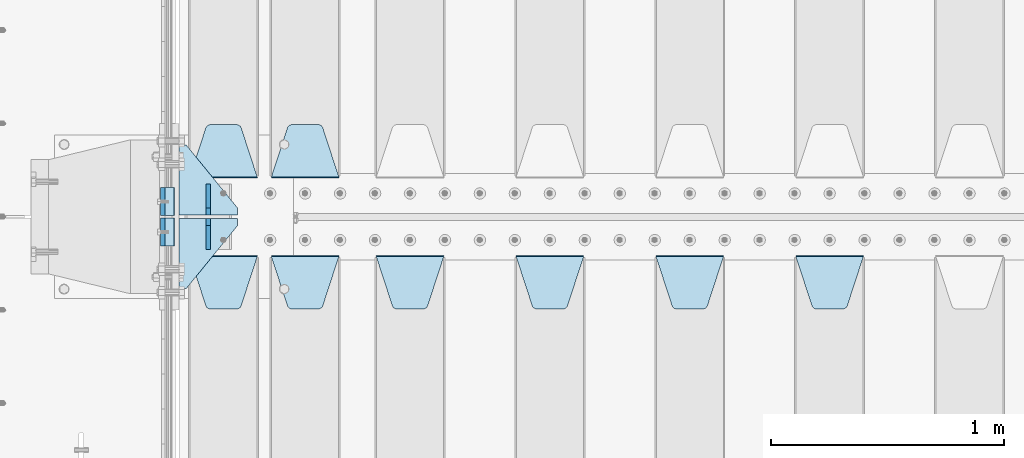
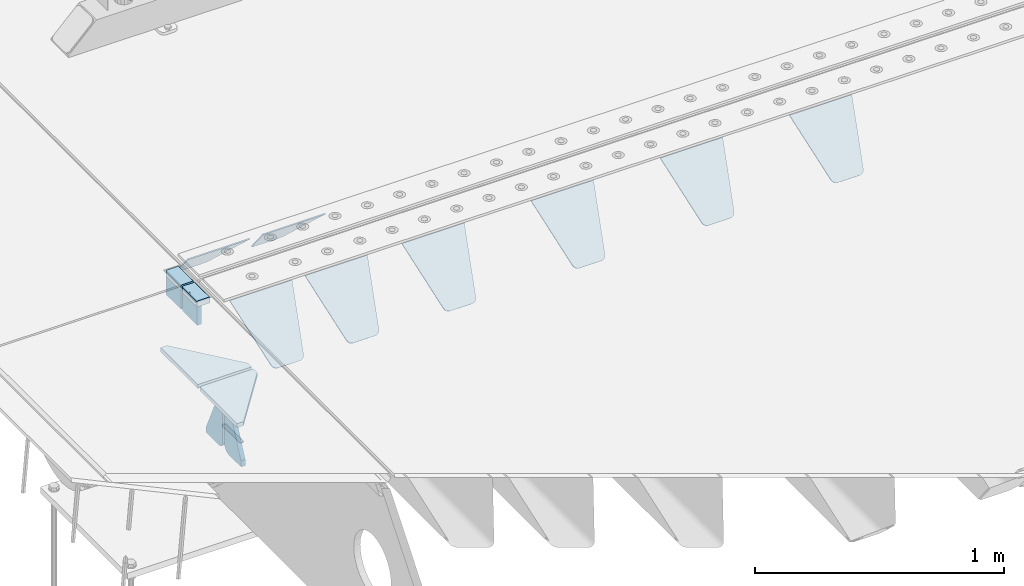
# One storey, part 217 of 257: 16 plates.
"""IFC2X3 building model written with IfcOpenShell, lengths in millimetres."""

from ifc_helpers import new_model, si_unit, frame, origin_with_axes, place, context, subcontext, project, spatial, faceted_brep, material, type_object, element, save


model = new_model("IFC2X3")

# Units and contexts
model_context = context("Model", 3, precision=1e-05, world=origin_with_axes())
body_context = subcontext(model_context, "Body", "Model", "MODEL_VIEW")
ifc_project = project(units=[si_unit("LENGTHUNIT", "METRE", prefix="MILLI"), si_unit("AREAUNIT", "SQUARE_METRE"), si_unit("VOLUMEUNIT", "CUBIC_METRE"), si_unit("MASSUNIT", "GRAM", prefix="KILO"), si_unit("TIMEUNIT", "SECOND"), si_unit("PLANEANGLEUNIT", "RADIAN"), si_unit("SOLIDANGLEUNIT", "STERADIAN"), si_unit("THERMODYNAMICTEMPERATUREUNIT", "DEGREE_CELSIUS"), si_unit("LUMINOUSINTENSITYUNIT", "LUMEN")], contexts=[model_context])

# Site, building, storey
site_placement = place(None, origin_with_axes())
site = spatial("IfcSite", under=ifc_project, at=site_placement, CompositionType="ELEMENT")
building_placement = place(site_placement, origin_with_axes())
building = spatial("IfcBuilding", under=site, at=building_placement, Name="Standard", CompositionType="ELEMENT")
storey_placement = place(building_placement, origin_with_axes())
storey = spatial("IfcBuildingStorey", under=building, at=storey_placement, Name="Undefined", CompositionType="ELEMENT", Elevation=0.0)

# Plates
ifc_material_1 = material()
plate_type_1 = type_object("IfcPlateType", PredefinedType="NOTDEFINED")
for number, where, z_axis, x_axis in (
    (1, (42440.00000006, 8935.00000043354, -16.000386849525), (-1.0, 0.0, 0.0), (0.0, -4.95099999998473e-06, 0.999999999987744)),
    (2, (42439.99999994, 9065.00000043201, -15.9997432191214), (-1.0, 0.0, 0.0), (0.0, -4.95099999998473e-06, 0.999999999987744)),
):
    element("IfcPlate", number, at=place(storey_placement, frame(where, z_axis=z_axis, x_axis=x_axis)), inside=storey, type_object=plate_type_1, material=ifc_material_1, context=body_context, shape_type="Brep", body=[
        faceted_brep([(0.0, -60.0, 0.0), (-0.000933120085687023, -60.0, 60.0), (-0.000933120085687023, 60.0, 59.9999999999927), (0.0, 60.0, -7.27595761418343e-12), (24.9991450303709, -60.0, 60.0), (24.9991450303709, 60.0, 59.9999999999927), (26.544215218168, -60.0, 59.7552873850873), (26.544215218168, 60.0, 59.75528738508), (27.9380461396139, -60.0, 59.0451032459096), (27.9380461396139, 60.0, 59.0451032459096), (29.0442025908961, -60.0, 57.9389639895744), (29.0442025908961, 60.0, 57.9389639895744), (29.7544083969366, -60.0, 56.5451441080368), (29.7544083969366, 60.0, 56.5451441080295), (29.9991450297669, -60.0, 55.0000777244568), (29.9991450297669, 60.0, 55.0000777244495), (29.999922274335, -60.0, 5.00007772445679), (29.999922274335, 60.0, 5.00007772444951), (29.7552240705896, -60.0, 3.45497416452417), (29.7552240705896, 60.0, 3.45497416452417), (29.0450346578116, -60.0, 2.06111146690819), (29.0450346578116, 60.0, 2.06111146690819), (27.9388736885072, -60.0, 0.954933302316931), (27.9388736885072, 60.0, 0.954933302316931), (26.5450220308766, -60.0, 0.244722222181736), (26.5450220308766, 60.0, 0.244722222181736), (24.9999222749392, -60.0, 0.0), (24.9999222749392, 60.0, -7.27595761418343e-12)], [[[0, 1, 2, 3]], [[1, 4, 5, 2]], [[4, 6, 7, 5]], [[6, 8, 9, 7]], [[8, 10, 11, 9]], [[10, 12, 13, 11]], [[12, 14, 15, 13]], [[14, 16, 17, 15]], [[16, 18, 19, 17]], [[18, 20, 21, 19]], [[20, 22, 23, 21]], [[22, 24, 25, 23]], [[24, 26, 27, 25]], [[26, 0, 3, 27]], [[5, 7, 9, 11, 13, 15, 17, 19, 21, 23, 25, 27, 3, 2]], [[26, 24, 22, 20, 18, 16, 14, 12, 10, 8, 6, 4, 1, 0]]]),
    ])
ifc_material_2 = material(Name="STEEL/S355N")
plate_type_2 = type_object("IfcPlateType", PredefinedType="NOTDEFINED")
for number, where, z_axis, x_axis in (
    (3, (42390.0, 8995.00044598306, -106.000711879208), (0.0, -0.999999999987744, -4.95099999993769e-06), (0.0, -4.95099999998473e-06, 0.999999999987744)),
    (4, (42390.0, 9125.00044598126, -106.000068249326), (0.0, -0.999999999987744, -4.95099999993769e-06), (0.0, -4.95099999998473e-06, 0.999999999987744)),
):
    element("IfcPlate", number, at=place(storey_placement, frame(where, z_axis=z_axis, x_axis=x_axis)), inside=storey, type_object=plate_type_2, material=ifc_material_2, context=body_context, shape_type="Brep", body=[
        faceted_brep([(0.0, -10.0, 0.0), (5.7072624315424e-07, -10.0, 120.0), (5.7072624315424e-07, 10.0, 120.0), (0.0, 10.0, 0.0), (90.0, -10.0, 120.0), (90.0, 10.0, 120.0), (90.0, -10.0, 1.09139364212751e-11), (90.0, 10.0, 1.09139364212751e-11)], [[[0, 1, 2, 3]], [[1, 4, 5, 2]], [[4, 6, 7, 5]], [[6, 0, 3, 7]], [[5, 7, 3, 2]], [[6, 4, 1, 0]]]),
    ])
plate_type_3 = type_object("IfcPlateType", PredefinedType="NOTDEFINED")
plate_1_placement = place(storey_placement, frame((45105.0, 8831.76776695594, -1.767766952965), z_axis=(0.0, -0.707106781186548, -0.707106781186547), x_axis=(1.0, 0.0, 0.0)))
element("IfcPlate", 5, at=plate_1_placement, inside=storey, type_object=plate_type_3, material=ifc_material_2, context=body_context, shape_type="Brep", body=[
    faceted_brep([(0.0, -2.5, 0.0), (69.345504679477, -2.50000000000091, 300.17173142483), (69.345504679477, 2.5, 300.171731424831), (0.0, 2.5, 0.0), (70.927406119954, -2.50000000000091, 304.8974424154), (70.927406119954, 2.5, 304.8974424154), (73.3818627772271, -2.50000000000091, 309.234538108527), (73.3818627772271, 2.49999999999909, 309.234538108527), (76.6187032999587, -2.5, 313.023683126103), (76.6187032999587, 2.5, 313.023683126103), (80.5190132705029, -2.5, 316.125672595372), (80.5190132705029, 2.5, 316.125672595371), (84.9395038596849, -2.5, 318.426546230476), (84.9395038596849, 2.5, 318.426546230477), (89.7177759439219, -2.5, 319.841774983275), (89.7177759439219, 2.5, 319.841774983275), (94.6782862926484, -2.5, 320.319366455079), (94.6782862926484, 2.5, 320.319366455079), (195.321713707352, -2.5, 320.319366455079), (195.321713707352, 2.5, 320.319366455079), (200.282224056078, -2.5, 319.841774983275), (200.282224056078, 2.49999999999909, 319.841774983275), (205.060496140315, -2.5, 318.426546230476), (205.060496140315, 2.49999999999909, 318.426546230475), (209.480986729497, -2.5, 316.125672595371), (209.480986729497, 2.5, 316.125672595371), (213.381296700041, -2.50000000000091, 313.023683126102), (213.381296700041, 2.5, 313.023683126103), (216.618137222766, -2.50000000000091, 309.234538108527), (216.618137222766, 2.5, 309.234538108527), (219.072593880039, -2.5, 304.897442415399), (219.072593880039, 2.5, 304.897442415399), (220.654495320523, -2.50000000000091, 300.17173142483), (220.654495320523, 2.5, 300.171731424831), (290.0, -2.50000000000091, 0.0), (290.0, 2.5, 9.09494701772928e-13)], [[[0, 1, 2, 3]], [[1, 4, 5, 2]], [[4, 6, 7, 5]], [[6, 8, 9, 7]], [[8, 10, 11, 9]], [[10, 12, 13, 11]], [[12, 14, 15, 13]], [[14, 16, 17, 15]], [[16, 18, 19, 17]], [[18, 20, 21, 19]], [[20, 22, 23, 21]], [[22, 24, 25, 23]], [[24, 26, 27, 25]], [[26, 28, 29, 27]], [[28, 30, 31, 29]], [[30, 32, 33, 31]], [[32, 34, 35, 33]], [[34, 0, 3, 35]], [[5, 7, 9, 11, 13, 15, 17, 19, 21, 23, 25, 27, 29, 31, 33, 35, 3, 2]], [[34, 32, 30, 28, 26, 24, 22, 20, 18, 16, 14, 12, 10, 8, 6, 4, 1, 0]]]),
])
plate_2_placement = place(storey_placement, frame((44505.0, 8831.76776695594, -1.767766952965), z_axis=(0.0, -0.707106781186548, -0.707106781186547), x_axis=(1.0, 0.0, 0.0)))
element("IfcPlate", 6, at=plate_2_placement, inside=storey, type_object=plate_type_3, material=ifc_material_2, context=body_context, shape_type="Brep", body=[
    faceted_brep([(0.0, -2.5, 0.0), (69.345504679477, -2.50000000000091, 300.17173142483), (69.345504679477, 2.5, 300.171731424831), (0.0, 2.5, 0.0), (70.927406119954, -2.50000000000091, 304.8974424154), (70.927406119954, 2.5, 304.8974424154), (73.3818627772271, -2.50000000000091, 309.234538108527), (73.3818627772271, 2.49999999999909, 309.234538108527), (76.6187032999587, -2.5, 313.023683126103), (76.6187032999587, 2.5, 313.023683126103), (80.5190132705029, -2.5, 316.125672595372), (80.5190132705029, 2.5, 316.125672595371), (84.9395038596849, -2.5, 318.426546230476), (84.9395038596849, 2.5, 318.426546230477), (89.7177759439219, -2.5, 319.841774983275), (89.7177759439219, 2.5, 319.841774983275), (94.6782862926484, -2.5, 320.319366455079), (94.6782862926484, 2.5, 320.319366455079), (195.321713707352, -2.5, 320.319366455079), (195.321713707352, 2.5, 320.319366455079), (200.282224056078, -2.5, 319.841774983275), (200.282224056078, 2.49999999999909, 319.841774983275), (205.060496140315, -2.5, 318.426546230476), (205.060496140315, 2.49999999999909, 318.426546230475), (209.480986729497, -2.5, 316.125672595371), (209.480986729497, 2.5, 316.125672595371), (213.381296700041, -2.50000000000091, 313.023683126102), (213.381296700041, 2.5, 313.023683126103), (216.618137222766, -2.50000000000091, 309.234538108527), (216.618137222766, 2.5, 309.234538108527), (219.072593880039, -2.5, 304.897442415399), (219.072593880039, 2.5, 304.897442415399), (220.654495320523, -2.50000000000091, 300.17173142483), (220.654495320523, 2.5, 300.171731424831), (290.0, -2.50000000000091, 0.0), (290.0, 2.5, 9.09494701772928e-13)], [[[0, 1, 2, 3]], [[1, 4, 5, 2]], [[4, 6, 7, 5]], [[6, 8, 9, 7]], [[8, 10, 11, 9]], [[10, 12, 13, 11]], [[12, 14, 15, 13]], [[14, 16, 17, 15]], [[16, 18, 19, 17]], [[18, 20, 21, 19]], [[20, 22, 23, 21]], [[22, 24, 25, 23]], [[24, 26, 27, 25]], [[26, 28, 29, 27]], [[28, 30, 31, 29]], [[30, 32, 33, 31]], [[32, 34, 35, 33]], [[34, 0, 3, 35]], [[5, 7, 9, 11, 13, 15, 17, 19, 21, 23, 25, 27, 29, 31, 33, 35, 3, 2]], [[34, 32, 30, 28, 26, 24, 22, 20, 18, 16, 14, 12, 10, 8, 6, 4, 1, 0]]]),
])
plate_3_placement = place(storey_placement, frame((43905.0, 8831.76776695594, -1.767766952965), z_axis=(0.0, -0.707106781186548, -0.707106781186547), x_axis=(1.0, 0.0, 0.0)))
element("IfcPlate", 7, at=plate_3_placement, inside=storey, type_object=plate_type_3, material=ifc_material_2, context=body_context, shape_type="Brep", body=[
    faceted_brep([(0.0, -2.5, 0.0), (69.345504679477, -2.50000000000091, 300.17173142483), (69.345504679477, 2.5, 300.171731424831), (0.0, 2.5, 0.0), (70.927406119954, -2.50000000000091, 304.8974424154), (70.927406119954, 2.5, 304.8974424154), (73.3818627772271, -2.50000000000091, 309.234538108527), (73.3818627772271, 2.49999999999909, 309.234538108527), (76.6187032999587, -2.5, 313.023683126103), (76.6187032999587, 2.5, 313.023683126103), (80.5190132705029, -2.5, 316.125672595372), (80.5190132705029, 2.5, 316.125672595371), (84.9395038596849, -2.5, 318.426546230476), (84.9395038596849, 2.5, 318.426546230477), (89.7177759439219, -2.5, 319.841774983275), (89.7177759439219, 2.5, 319.841774983275), (94.6782862926484, -2.5, 320.319366455079), (94.6782862926484, 2.5, 320.319366455079), (195.321713707352, -2.5, 320.319366455079), (195.321713707352, 2.5, 320.319366455079), (200.282224056078, -2.5, 319.841774983275), (200.282224056078, 2.49999999999909, 319.841774983275), (205.060496140315, -2.5, 318.426546230476), (205.060496140315, 2.49999999999909, 318.426546230475), (209.480986729497, -2.5, 316.125672595371), (209.480986729497, 2.5, 316.125672595371), (213.381296700041, -2.50000000000091, 313.023683126102), (213.381296700041, 2.5, 313.023683126103), (216.618137222766, -2.50000000000091, 309.234538108527), (216.618137222766, 2.5, 309.234538108527), (219.072593880039, -2.5, 304.897442415399), (219.072593880039, 2.5, 304.897442415399), (220.654495320523, -2.50000000000091, 300.17173142483), (220.654495320523, 2.5, 300.171731424831), (290.0, -2.50000000000091, 0.0), (290.0, 2.5, 9.09494701772928e-13)], [[[0, 1, 2, 3]], [[1, 4, 5, 2]], [[4, 6, 7, 5]], [[6, 8, 9, 7]], [[8, 10, 11, 9]], [[10, 12, 13, 11]], [[12, 14, 15, 13]], [[14, 16, 17, 15]], [[16, 18, 19, 17]], [[18, 20, 21, 19]], [[20, 22, 23, 21]], [[22, 24, 25, 23]], [[24, 26, 27, 25]], [[26, 28, 29, 27]], [[28, 30, 31, 29]], [[30, 32, 33, 31]], [[32, 34, 35, 33]], [[34, 0, 3, 35]], [[5, 7, 9, 11, 13, 15, 17, 19, 21, 23, 25, 27, 29, 31, 33, 35, 3, 2]], [[34, 32, 30, 28, 26, 24, 22, 20, 18, 16, 14, 12, 10, 8, 6, 4, 1, 0]]]),
])
plate_4_placement = place(storey_placement, frame((43305.0, 8831.76776695594, -1.767766952965), z_axis=(0.0, -0.707106781186548, -0.707106781186547), x_axis=(1.0, 0.0, 0.0)))
element("IfcPlate", 8, at=plate_4_placement, inside=storey, type_object=plate_type_3, material=ifc_material_2, context=body_context, shape_type="Brep", body=[
    faceted_brep([(0.0, -2.5, 0.0), (69.345504679477, -2.50000000000091, 300.17173142483), (69.345504679477, 2.5, 300.171731424831), (0.0, 2.5, 0.0), (70.927406119954, -2.50000000000091, 304.8974424154), (70.927406119954, 2.5, 304.8974424154), (73.3818627772271, -2.50000000000091, 309.234538108527), (73.3818627772271, 2.49999999999909, 309.234538108527), (76.6187032999587, -2.5, 313.023683126103), (76.6187032999587, 2.5, 313.023683126103), (80.5190132705029, -2.5, 316.125672595372), (80.5190132705029, 2.5, 316.125672595371), (84.9395038596849, -2.5, 318.426546230476), (84.9395038596849, 2.5, 318.426546230477), (89.7177759439219, -2.5, 319.841774983275), (89.7177759439219, 2.5, 319.841774983275), (94.6782862926484, -2.5, 320.319366455079), (94.6782862926484, 2.5, 320.319366455079), (195.321713707352, -2.5, 320.319366455079), (195.321713707352, 2.5, 320.319366455079), (200.282224056078, -2.5, 319.841774983275), (200.282224056078, 2.49999999999909, 319.841774983275), (205.060496140315, -2.5, 318.426546230476), (205.060496140315, 2.49999999999909, 318.426546230475), (209.480986729497, -2.5, 316.125672595371), (209.480986729497, 2.5, 316.125672595371), (213.381296700041, -2.50000000000091, 313.023683126102), (213.381296700041, 2.5, 313.023683126103), (216.618137222766, -2.50000000000091, 309.234538108527), (216.618137222766, 2.5, 309.234538108527), (219.072593880039, -2.5, 304.897442415399), (219.072593880039, 2.5, 304.897442415399), (220.654495320523, -2.50000000000091, 300.17173142483), (220.654495320523, 2.5, 300.171731424831), (290.0, -2.50000000000091, 0.0), (290.0, 2.5, 9.09494701772928e-13)], [[[0, 1, 2, 3]], [[1, 4, 5, 2]], [[4, 6, 7, 5]], [[6, 8, 9, 7]], [[8, 10, 11, 9]], [[10, 12, 13, 11]], [[12, 14, 15, 13]], [[14, 16, 17, 15]], [[16, 18, 19, 17]], [[18, 20, 21, 19]], [[20, 22, 23, 21]], [[22, 24, 25, 23]], [[24, 26, 27, 25]], [[26, 28, 29, 27]], [[28, 30, 31, 29]], [[30, 32, 33, 31]], [[32, 34, 35, 33]], [[34, 0, 3, 35]], [[5, 7, 9, 11, 13, 15, 17, 19, 21, 23, 25, 27, 29, 31, 33, 35, 3, 2]], [[34, 32, 30, 28, 26, 24, 22, 20, 18, 16, 14, 12, 10, 8, 6, 4, 1, 0]]]),
])
plate_5_placement = place(storey_placement, frame((42855.0, 8831.76776695594, -1.767766952965), z_axis=(0.0, -0.707106781186548, -0.707106781186547), x_axis=(1.0, 0.0, 0.0)))
element("IfcPlate", 9, at=plate_5_placement, inside=storey, type_object=plate_type_3, material=ifc_material_2, context=body_context, shape_type="Brep", body=[
    faceted_brep([(0.0, -2.5, 0.0), (69.345504679477, -2.50000000000091, 300.17173142483), (69.345504679477, 2.5, 300.171731424831), (0.0, 2.5, 0.0), (70.927406119954, -2.50000000000091, 304.8974424154), (70.927406119954, 2.5, 304.8974424154), (73.3818627772271, -2.50000000000091, 309.234538108527), (73.3818627772271, 2.49999999999909, 309.234538108527), (76.6187032999587, -2.5, 313.023683126103), (76.6187032999587, 2.5, 313.023683126103), (80.5190132705029, -2.5, 316.125672595372), (80.5190132705029, 2.5, 316.125672595371), (84.9395038596849, -2.5, 318.426546230476), (84.9395038596849, 2.5, 318.426546230477), (89.7177759439219, -2.5, 319.841774983275), (89.7177759439219, 2.5, 319.841774983275), (94.6782862926484, -2.5, 320.319366455079), (94.6782862926484, 2.5, 320.319366455079), (195.321713707352, -2.5, 320.319366455079), (195.321713707352, 2.5, 320.319366455079), (200.282224056078, -2.5, 319.841774983275), (200.282224056078, 2.49999999999909, 319.841774983275), (205.060496140315, -2.5, 318.426546230476), (205.060496140315, 2.49999999999909, 318.426546230475), (209.480986729497, -2.5, 316.125672595371), (209.480986729497, 2.5, 316.125672595371), (213.381296700041, -2.50000000000091, 313.023683126102), (213.381296700041, 2.5, 313.023683126103), (216.618137222766, -2.50000000000091, 309.234538108527), (216.618137222766, 2.5, 309.234538108527), (219.072593880039, -2.5, 304.897442415399), (219.072593880039, 2.5, 304.897442415399), (220.654495320523, -2.50000000000091, 300.17173142483), (220.654495320523, 2.5, 300.171731424831), (290.0, -2.50000000000091, 0.0), (290.0, 2.5, 9.09494701772928e-13)], [[[0, 1, 2, 3]], [[1, 4, 5, 2]], [[4, 6, 7, 5]], [[6, 8, 9, 7]], [[8, 10, 11, 9]], [[10, 12, 13, 11]], [[12, 14, 15, 13]], [[14, 16, 17, 15]], [[16, 18, 19, 17]], [[18, 20, 21, 19]], [[20, 22, 23, 21]], [[22, 24, 25, 23]], [[24, 26, 27, 25]], [[26, 28, 29, 27]], [[28, 30, 31, 29]], [[30, 32, 33, 31]], [[32, 34, 35, 33]], [[34, 0, 3, 35]], [[5, 7, 9, 11, 13, 15, 17, 19, 21, 23, 25, 27, 29, 31, 33, 35, 3, 2]], [[34, 32, 30, 28, 26, 24, 22, 20, 18, 16, 14, 12, 10, 8, 6, 4, 1, 0]]]),
])
plate_6_placement = place(storey_placement, frame((43145.0, 9168.23223304703, -1.76776695296758), z_axis=(0.0, 0.707106781186547, -0.707106781186548), x_axis=(-1.0, 0.0, 0.0)))
element("IfcPlate", 10, at=plate_6_placement, inside=storey, type_object=plate_type_3, material=ifc_material_2, context=body_context, shape_type="Brep", body=[
    faceted_brep([(0.0, -2.5, 0.0), (69.345504679477, -2.50000000000091, 300.17173142483), (69.345504679477, 2.5, 300.171731424831), (0.0, 2.5, 0.0), (70.927406119954, -2.50000000000091, 304.8974424154), (70.927406119954, 2.5, 304.8974424154), (73.3818627772271, -2.50000000000091, 309.234538108527), (73.3818627772271, 2.49999999999909, 309.234538108527), (76.6187032999587, -2.5, 313.023683126103), (76.6187032999587, 2.5, 313.023683126103), (80.5190132705029, -2.5, 316.125672595372), (80.5190132705029, 2.5, 316.125672595371), (84.9395038596849, -2.5, 318.426546230476), (84.9395038596849, 2.5, 318.426546230477), (89.7177759439219, -2.5, 319.841774983275), (89.7177759439219, 2.5, 319.841774983275), (94.6782862926484, -2.5, 320.319366455079), (94.6782862926484, 2.5, 320.319366455079), (195.321713707352, -2.5, 320.319366455079), (195.321713707352, 2.5, 320.319366455079), (200.282224056078, -2.5, 319.841774983275), (200.282224056078, 2.49999999999909, 319.841774983275), (205.060496140315, -2.5, 318.426546230476), (205.060496140315, 2.49999999999909, 318.426546230475), (209.480986729497, -2.5, 316.125672595371), (209.480986729497, 2.5, 316.125672595371), (213.381296700041, -2.50000000000091, 313.023683126102), (213.381296700041, 2.5, 313.023683126103), (216.618137222766, -2.50000000000091, 309.234538108527), (216.618137222766, 2.5, 309.234538108527), (219.072593880039, -2.5, 304.897442415399), (219.072593880039, 2.5, 304.897442415399), (220.654495320523, -2.50000000000091, 300.17173142483), (220.654495320523, 2.5, 300.171731424831), (290.0, -2.50000000000091, 0.0), (290.0, 2.5, 9.09494701772928e-13)], [[[0, 1, 2, 3]], [[1, 4, 5, 2]], [[4, 6, 7, 5]], [[6, 8, 9, 7]], [[8, 10, 11, 9]], [[10, 12, 13, 11]], [[12, 14, 15, 13]], [[14, 16, 17, 15]], [[16, 18, 19, 17]], [[18, 20, 21, 19]], [[20, 22, 23, 21]], [[22, 24, 25, 23]], [[24, 26, 27, 25]], [[26, 28, 29, 27]], [[28, 30, 31, 29]], [[30, 32, 33, 31]], [[32, 34, 35, 33]], [[34, 0, 3, 35]], [[5, 7, 9, 11, 13, 15, 17, 19, 21, 23, 25, 27, 29, 31, 33, 35, 3, 2]], [[34, 32, 30, 28, 26, 24, 22, 20, 18, 16, 14, 12, 10, 8, 6, 4, 1, 0]]]),
])
plate_7_placement = place(storey_placement, frame((42505.0, 8831.76776695594, -1.767766952965), z_axis=(0.0, -0.707106781186548, -0.707106781186547), x_axis=(1.0, 0.0, 0.0)))
element("IfcPlate", 11, at=plate_7_placement, inside=storey, type_object=plate_type_3, material=ifc_material_2, context=body_context, shape_type="Brep", body=[
    faceted_brep([(0.0, -2.5, 0.0), (69.345504679477, -2.50000000000091, 300.17173142483), (69.345504679477, 2.5, 300.171731424831), (0.0, 2.5, 0.0), (70.927406119954, -2.50000000000091, 304.8974424154), (70.927406119954, 2.5, 304.8974424154), (73.3818627772271, -2.50000000000091, 309.234538108527), (73.3818627772271, 2.49999999999909, 309.234538108527), (76.6187032999587, -2.5, 313.023683126103), (76.6187032999587, 2.5, 313.023683126103), (80.5190132705029, -2.5, 316.125672595372), (80.5190132705029, 2.5, 316.125672595371), (84.9395038596849, -2.5, 318.426546230476), (84.9395038596849, 2.5, 318.426546230477), (89.7177759439219, -2.5, 319.841774983275), (89.7177759439219, 2.5, 319.841774983275), (94.6782862926484, -2.5, 320.319366455079), (94.6782862926484, 2.5, 320.319366455079), (195.321713707352, -2.5, 320.319366455079), (195.321713707352, 2.5, 320.319366455079), (200.282224056078, -2.5, 319.841774983275), (200.282224056078, 2.49999999999909, 319.841774983275), (205.060496140315, -2.5, 318.426546230476), (205.060496140315, 2.49999999999909, 318.426546230475), (209.480986729497, -2.5, 316.125672595371), (209.480986729497, 2.5, 316.125672595371), (213.381296700041, -2.50000000000091, 313.023683126102), (213.381296700041, 2.5, 313.023683126103), (216.618137222766, -2.50000000000091, 309.234538108527), (216.618137222766, 2.5, 309.234538108527), (219.072593880039, -2.5, 304.897442415399), (219.072593880039, 2.5, 304.897442415399), (220.654495320523, -2.50000000000091, 300.17173142483), (220.654495320523, 2.5, 300.171731424831), (290.0, -2.50000000000091, 0.0), (290.0, 2.5, 9.09494701772928e-13)], [[[0, 1, 2, 3]], [[1, 4, 5, 2]], [[4, 6, 7, 5]], [[6, 8, 9, 7]], [[8, 10, 11, 9]], [[10, 12, 13, 11]], [[12, 14, 15, 13]], [[14, 16, 17, 15]], [[16, 18, 19, 17]], [[18, 20, 21, 19]], [[20, 22, 23, 21]], [[22, 24, 25, 23]], [[24, 26, 27, 25]], [[26, 28, 29, 27]], [[28, 30, 31, 29]], [[30, 32, 33, 31]], [[32, 34, 35, 33]], [[34, 0, 3, 35]], [[5, 7, 9, 11, 13, 15, 17, 19, 21, 23, 25, 27, 29, 31, 33, 35, 3, 2]], [[34, 32, 30, 28, 26, 24, 22, 20, 18, 16, 14, 12, 10, 8, 6, 4, 1, 0]]]),
])
plate_8_placement = place(storey_placement, frame((42795.0, 9168.23223304703, -1.76776695296758), z_axis=(0.0, 0.707106781186547, -0.707106781186548), x_axis=(-1.0, 0.0, 0.0)))
element("IfcPlate", 12, at=plate_8_placement, inside=storey, type_object=plate_type_3, material=ifc_material_2, context=body_context, shape_type="Brep", body=[
    faceted_brep([(0.0, -2.5, 0.0), (69.345504679477, -2.50000000000091, 300.17173142483), (69.345504679477, 2.5, 300.171731424831), (0.0, 2.5, 0.0), (70.927406119954, -2.50000000000091, 304.8974424154), (70.927406119954, 2.5, 304.8974424154), (73.3818627772271, -2.50000000000091, 309.234538108527), (73.3818627772271, 2.49999999999909, 309.234538108527), (76.6187032999587, -2.5, 313.023683126103), (76.6187032999587, 2.5, 313.023683126103), (80.5190132705029, -2.5, 316.125672595372), (80.5190132705029, 2.5, 316.125672595371), (84.9395038596849, -2.5, 318.426546230476), (84.9395038596849, 2.5, 318.426546230477), (89.7177759439219, -2.5, 319.841774983275), (89.7177759439219, 2.5, 319.841774983275), (94.6782862926484, -2.5, 320.319366455079), (94.6782862926484, 2.5, 320.319366455079), (195.321713707352, -2.5, 320.319366455079), (195.321713707352, 2.5, 320.319366455079), (200.282224056078, -2.5, 319.841774983275), (200.282224056078, 2.49999999999909, 319.841774983275), (205.060496140315, -2.5, 318.426546230476), (205.060496140315, 2.49999999999909, 318.426546230475), (209.480986729497, -2.5, 316.125672595371), (209.480986729497, 2.5, 316.125672595371), (213.381296700041, -2.50000000000091, 313.023683126102), (213.381296700041, 2.5, 313.023683126103), (216.618137222766, -2.50000000000091, 309.234538108527), (216.618137222766, 2.5, 309.234538108527), (219.072593880039, -2.5, 304.897442415399), (219.072593880039, 2.5, 304.897442415399), (220.654495320523, -2.50000000000091, 300.17173142483), (220.654495320523, 2.5, 300.171731424831), (290.0, -2.50000000000091, 0.0), (290.0, 2.5, 9.09494701772928e-13)], [[[0, 1, 2, 3]], [[1, 4, 5, 2]], [[4, 6, 7, 5]], [[6, 8, 9, 7]], [[8, 10, 11, 9]], [[10, 12, 13, 11]], [[12, 14, 15, 13]], [[14, 16, 17, 15]], [[16, 18, 19, 17]], [[18, 20, 21, 19]], [[20, 22, 23, 21]], [[22, 24, 25, 23]], [[24, 26, 27, 25]], [[26, 28, 29, 27]], [[28, 30, 31, 29]], [[30, 32, 33, 31]], [[32, 34, 35, 33]], [[34, 0, 3, 35]], [[5, 7, 9, 11, 13, 15, 17, 19, 21, 23, 25, 27, 29, 31, 33, 35, 3, 2]], [[34, 32, 30, 28, 26, 24, 22, 20, 18, 16, 14, 12, 10, 8, 6, 4, 1, 0]]]),
])
plate_type_4 = type_object("IfcPlateType", PredefinedType="NOTDEFINED")
for number, where, z_axis, x_axis in (
    (13, (42710.0, 9008.0, -515.0), (0.0, 1.0, 0.0), (-1.0, 0.0, 0.0)),
    (14, (42710.0, 8992.0, -515.0), (0.0, -1.0, 0.0), (-1.0, 0.0, 0.0)),
):
    element("IfcPlate", number, at=place(storey_placement, frame(where, z_axis=z_axis, x_axis=x_axis)), inside=storey, type_object=plate_type_4, material=ifc_material_2, context=body_context, shape_type="Brep", body=[
        faceted_brep([(0.0, -10.0, 0.0), (0.0, -10.0, 30.0), (0.0, 10.0, 30.0), (0.0, 10.0, 0.0), (220.0, -10.0, 300.0), (220.0, 10.0, 300.0), (250.0, -10.0, 300.0), (250.0, 10.0, 300.0), (250.0, -10.0, 0.0), (250.0, 10.0, 0.0)], [[[0, 1, 2, 3]], [[1, 4, 5, 2]], [[4, 6, 7, 5]], [[6, 8, 9, 7]], [[8, 0, 3, 9]], [[5, 7, 9, 3, 2]], [[8, 6, 4, 1, 0]]]),
    ])
plate_type_5 = type_object("IfcPlateType", PredefinedType="NOTDEFINED")
for number, where, z_axis, x_axis in (
    (15, (42585.0, 9140.0, -860.0), (0.0, 0.0, 1.0), (0.0, -1.0, 0.0)),
    (16, (42585.0, 8860.0, -860.0), (0.0, 0.0, 1.0), (0.0, 1.0, 0.0)),
):
    element("IfcPlate", number, at=place(storey_placement, frame(where, z_axis=z_axis, x_axis=x_axis)), inside=storey, type_object=plate_type_5, material=ifc_material_2, context=body_context, shape_type="Brep", body=[
        faceted_brep([(0.0, -10.0, 0.0), (0.0, -10.0, 30.0), (0.0, 10.0, 30.0), (0.0, 10.0, 0.0), (102.0, -10.0, 250.0), (102.0, 10.0, 250.0), (132.0, -10.0, 250.0), (132.0, 10.0, 250.0), (132.0, -10.0, 30.0), (132.0, 10.0, 30.0), (131.544232590366, -10.0, 24.790554669992), (131.544232590366, 10.0, 24.790554669992), (130.190778623577, -10.0, 19.7393957002299), (130.190778623577, 10.0, 19.7393957002299), (127.980762113533, -10.0, 15.0), (127.980762113533, 10.0, 15.0), (124.981333293569, -10.0, 10.7163717094038), (124.981333293569, 10.0, 10.7163717094038), (121.283628290596, -10.0, 7.01866670643062), (121.283628290596, 10.0, 7.01866670643062), (117.0, -10.0, 4.01923788646684), (117.0, 10.0, 4.01923788646684), (112.26060429977, -10.0, 1.80922137642278), (112.26060429977, 10.0, 1.80922137642278), (107.209445330008, -10.0, 0.455767409633722), (107.209445330008, 10.0, 0.455767409633722), (102.0, -10.0, 0.0), (102.0, 10.0, 0.0)], [[[0, 1, 2, 3]], [[1, 4, 5, 2]], [[4, 6, 7, 5]], [[6, 8, 9, 7]], [[8, 10, 11, 9]], [[10, 12, 13, 11]], [[12, 14, 15, 13]], [[14, 16, 17, 15]], [[16, 18, 19, 17]], [[18, 20, 21, 19]], [[20, 22, 23, 21]], [[22, 24, 25, 23]], [[24, 26, 27, 25]], [[26, 0, 3, 27]], [[5, 7, 9, 11, 13, 15, 17, 19, 21, 23, 25, 27, 3, 2]], [[26, 24, 22, 20, 18, 16, 14, 12, 10, 8, 6, 4, 1, 0]]]),
    ])

save(model, "model.ifc")
